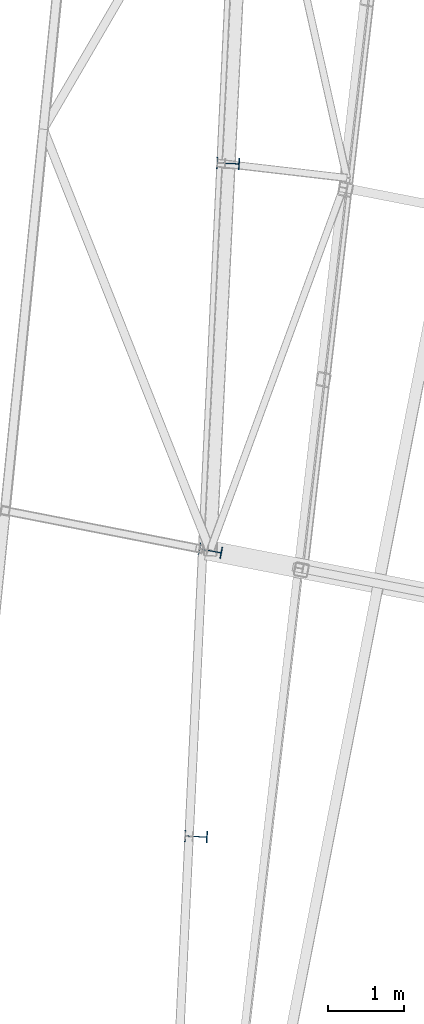
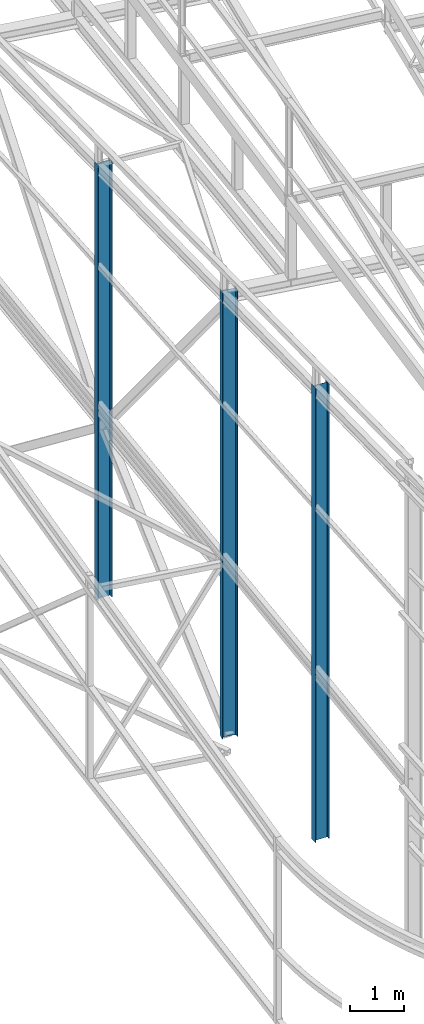
# One storey, part 1 of 215: 3 columns, 3 elements without a shape of their own.
"""IFC2X3 building model written with IfcOpenShell, lengths in millimetres."""

from ifc_helpers import new_model, si_unit, frame, origin_with_axes, origin_2d_with_axis, place, context, subcontext, project, spatial, i_section, extrude, material, type_object, element, aggregate, save


model = new_model("IFC2X3")

# Units and contexts
model_context = context("Model", 3, precision=1e-05, world=origin_with_axes())
body_context = subcontext(model_context, "Body", "Model", "MODEL_VIEW")
ifc_project = project(units=[si_unit("LENGTHUNIT", "METRE", prefix="MILLI"), si_unit("AREAUNIT", "SQUARE_METRE"), si_unit("VOLUMEUNIT", "CUBIC_METRE"), si_unit("MASSUNIT", "GRAM", prefix="KILO"), si_unit("TIMEUNIT", "SECOND"), si_unit("PLANEANGLEUNIT", "RADIAN"), si_unit("SOLIDANGLEUNIT", "STERADIAN"), si_unit("THERMODYNAMICTEMPERATUREUNIT", "DEGREE_CELSIUS"), si_unit("LUMINOUSINTENSITYUNIT", "LUMEN")], contexts=[model_context])

# Site, building, storey
site_placement = place(None, origin_with_axes())
site = spatial("IfcSite", under=ifc_project, at=site_placement, CompositionType="ELEMENT")
building_placement = place(site_placement, origin_with_axes())
building = spatial("IfcBuilding", under=site, at=building_placement, Name="Undefined", CompositionType="ELEMENT")
storey_placement = place(building_placement, origin_with_axes())
storey = spatial("IfcBuildingStorey", under=building, at=storey_placement, Name="Undefined", CompositionType="ELEMENT", Elevation=0.0)

# Assembly, column
assembly_1_placement = place(storey_placement, origin_with_axes())
assembly_1 = element("IfcElementAssembly", 1, at=assembly_1_placement, inside=storey, Name="Steel Assembly", AssemblyPlace="NOTDEFINED", PredefinedType="RIGID_FRAME")
ifc_material = material(Name="STEEL/S275JR")
column_type = type_object("IfcColumnType", Name="IPE300", PredefinedType="NOTDEFINED")
column_1_placement = place(assembly_1_placement, frame((37514.1283439121, 20328.0752808747, 0.00149246280629106), z_axis=(0.0, 0.0, 1.0), x_axis=(-0.998865584637834, 0.0476187339827342, 0.0)))
column_1 = element("IfcColumn", 2, at=column_1_placement, type_object=column_type, material=ifc_material, Name="MONTANT", ObjectType="IPE300", context=body_context, shape_type="SweptSolid", body=[
    extrude(i_section(OverallWidth=150.0, OverallDepth=300.0, WebThickness=7.099999905, FlangeThickness=10.69999981, FilletRadius=15.0, at=origin_2d_with_axis()), frame((-7.27595761418343e-12, 0.0, 10330.8797559146), z_axis=(0.0, 0.0, -1.0), x_axis=(0.0, 1.0, 0.0)), (0.0, 0.0, 1.0), 10330.9),
])
aggregate(assembly_1, [column_1])

assembly_2_placement = place(storey_placement, origin_with_axes())
assembly_2 = element("IfcElementAssembly", 3, at=assembly_2_placement, inside=storey, Name="Steel Assembly", AssemblyPlace="NOTDEFINED", PredefinedType="RIGID_FRAME")
column_2_placement = place(assembly_2_placement, frame((37934.081942686, 29140.3629652947, 0.00149246242875791), z_axis=(0.0, 0.0, 1.0), x_axis=(-0.998865584637834, 0.0476187339827342, 0.0)))
column_2 = element("IfcColumn", 4, at=column_2_placement, type_object=column_type, material=ifc_material, Name="MONTANT", ObjectType="IPE300", context=body_context, shape_type="SweptSolid", body=[
    extrude(i_section(OverallWidth=150.0, OverallDepth=300.0, WebThickness=7.099999905, FlangeThickness=10.69999981, FilletRadius=15.0, at=origin_2d_with_axis()), frame((0.0, 3.63797880709171e-12, 9893.68703034468), z_axis=(0.0, 0.0, -1.0), x_axis=(0.0, 1.0, 0.0)), (0.0, 0.0, 1.0), 9893.7),
])
aggregate(assembly_2, [column_2])

assembly_3_placement = place(storey_placement, origin_with_axes())
assembly_3 = element("IfcElementAssembly", 5, at=assembly_3_placement, inside=storey, Name="Steel Assembly", AssemblyPlace="NOTDEFINED", PredefinedType="RIGID_FRAME")
column_3_placement = place(assembly_3_placement, frame((37702.4017271118, 24069.185821887, 0.00149219693048508), z_axis=(0.0, 0.0, 1.0), x_axis=(-0.981422412140383, 0.191859451027444, 0.0)))
column_3 = element("IfcColumn", 6, at=column_3_placement, type_object=column_type, material=ifc_material, Name="MONTANT", ObjectType="IPE300", context=body_context, shape_type="SweptSolid", body=[
    extrude(i_section(OverallWidth=150.0, OverallDepth=300.0, WebThickness=7.099999905, FlangeThickness=10.69999981, FilletRadius=15.0, at=origin_2d_with_axis()), frame((0.0, 3.63797880709171e-12, 10145.4870463362), z_axis=(0.0, 0.0, -1.0), x_axis=(0.0, 1.0, 0.0)), (0.0, 0.0, 1.0), 10145.5),
])
aggregate(assembly_3, [column_3])

save(model, "model.ifc")
